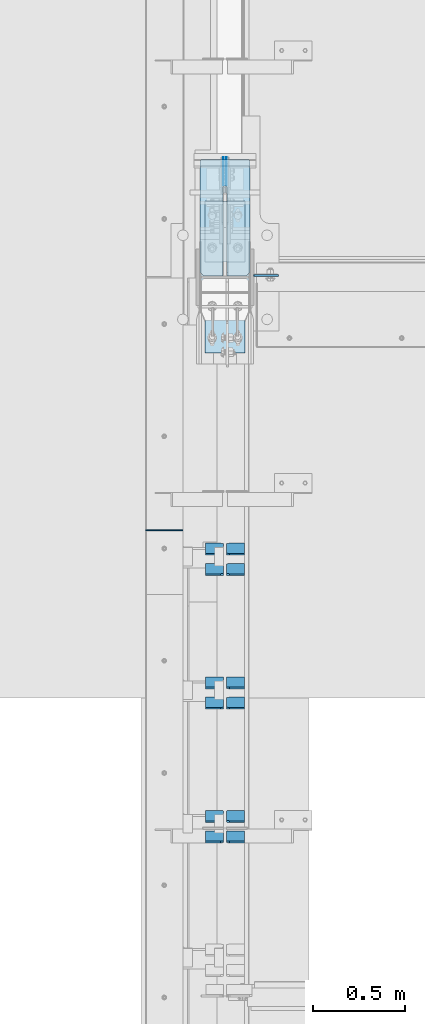
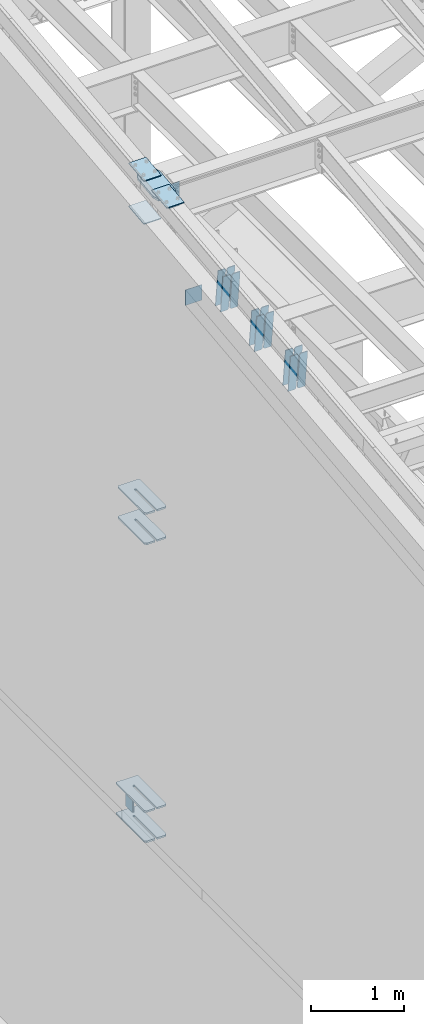
# One storey, part 1020 of 1179: 24 plates, 4 elements without a shape of their own.
"""IFC2X3 building model written with IfcOpenShell, lengths in millimetres."""

from ifc_helpers import new_model, si_unit, frame, origin_with_axes, place, context, subcontext, project, spatial, faceted_brep, material, type_object, element, aggregate, save


model = new_model("IFC2X3")

# Units and contexts
model_context = context("Model", 3, precision=1e-05, world=origin_with_axes())
body_context = subcontext(model_context, "Body", "Model", "MODEL_VIEW")
ifc_project = project(units=[si_unit("LENGTHUNIT", "METRE", prefix="MILLI"), si_unit("AREAUNIT", "SQUARE_METRE"), si_unit("VOLUMEUNIT", "CUBIC_METRE"), si_unit("MASSUNIT", "GRAM", prefix="KILO"), si_unit("TIMEUNIT", "SECOND"), si_unit("PLANEANGLEUNIT", "RADIAN"), si_unit("SOLIDANGLEUNIT", "STERADIAN"), si_unit("THERMODYNAMICTEMPERATUREUNIT", "DEGREE_CELSIUS"), si_unit("LUMINOUSINTENSITYUNIT", "LUMEN")], contexts=[model_context])

# Site, building, storey
site_placement = place(None, origin_with_axes())
site = spatial("IfcSite", under=ifc_project, at=site_placement, CompositionType="ELEMENT")
building_placement = place(site_placement, origin_with_axes())
building = spatial("IfcBuilding", under=site, at=building_placement, Name="Undefined", CompositionType="ELEMENT")
storey_placement = place(building_placement, origin_with_axes())
storey = spatial("IfcBuildingStorey", under=building, at=storey_placement, Name="Undefined", CompositionType="ELEMENT", Elevation=0.0)

# Assembly, plates
assembly_1_placement = place(storey_placement, origin_with_axes())
assembly_1 = element("IfcElementAssembly", 1, at=assembly_1_placement, inside=storey, Name="COLUMN", AssemblyPlace="NOTDEFINED", PredefinedType="RIGID_FRAME")
ifc_material_1 = material(Name="STEEL/A572-GR.50")
plate_type_1 = type_object("IfcPlateType", PredefinedType="NOTDEFINED")
plate_1_placement = place(assembly_1_placement, frame((295.274993896492, 27654.8389034115, 7605.7125), z_axis=(0.0, -1.0, 0.0), x_axis=(1.0, 0.0, 0.0)))
plate_1 = element("IfcPlate", 2, at=plate_1_placement, type_object=plate_type_1, material=ifc_material_1, Name="PLATE", context=body_context, shape_type="Brep", body=[
    faceted_brep([(125.41250610351, -11.1125000000002, 597.488903411475), (125.412506137872, -11.1125000000002, 153.988049705778), (125.412506137872, 11.1125000000002, 153.988049705778), (125.41250610351, 11.1125000000002, 597.488903411475), (126.258342274934, -11.1125000000002, 149.735606914768), (126.258342274934, 11.1125000000002, 149.735606914768), (128.667087804347, -11.1125000000002, 146.130519754093), (128.667087804347, 11.1125000000002, 146.130519754093), (132.272055845929, -11.1125000000002, 143.721595952742), (132.272055845929, 11.1125000000002, 143.721595952742), (136.524456006679, -11.1125000000002, 142.875549529541), (136.524456006679, 11.1125000000002, 142.875549529541), (140.777194472694, -11.1125000000002, 143.721280512222), (140.777194472694, 11.1125000000002, 143.721280512222), (144.382535483473, -11.1125000000002, 146.130131182439), (144.382535483473, 11.1125000000002, 146.130131182439), (146.79156443818, -11.1125000000002, 149.735353068929), (146.79156443818, 11.1125000000002, 149.735353068929), (147.63750572166, -11.1125000000002, 153.988049707568), (147.63750572166, 11.1125000000002, 153.988049707568), (147.637505687299, -11.1125000000002, 597.488903392987), (147.637505687299, 11.1125000000002, 597.488903411475), (0.0, -11.1125000000002, 575.263903030005), (22.2250003814697, -11.1125000000002, 597.488903411475), (22.2250003814697, 11.1125000000002, 597.488903411475), (0.0, 11.1125000000002, 575.263903030005), (0.0, -11.1125000000002, 15.875), (0.0, 11.1125000000002, 15.875), (6.34999990463257, -11.1125000000002, 0.0), (6.34999990463257, 11.1125000000002, 0.0), (266.699987888336, -11.1125000000002, 0.0), (266.699987888336, 11.1125000000002, 0.0), (273.049987792969, -11.1125000000002, 15.875), (273.049987792969, 11.1125000000002, 15.875), (273.050006103513, -11.1125000000002, 575.263903030005), (273.050006103513, 11.1125000000002, 575.263903030005), (250.825005722043, -11.1125000000002, 597.488903411475), (250.825005722043, 11.1125000000002, 597.488903411475)], [[[0, 1, 2, 3]], [[4, 5, 2, 1]], [[6, 7, 5, 4]], [[8, 9, 7, 6]], [[10, 11, 9, 8]], [[12, 13, 11, 10]], [[14, 15, 13, 12]], [[16, 17, 15, 14]], [[18, 19, 17, 16]], [[20, 21, 19, 18]], [[22, 23, 24, 25]], [[26, 22, 25, 27]], [[28, 26, 27, 29]], [[30, 28, 29, 31]], [[32, 30, 31, 33]], [[34, 32, 33, 35]], [[36, 34, 35, 37]], [[16, 14, 12, 10, 8, 6, 4, 1, 0, 23, 22, 26, 28, 30, 32, 34, 36, 20, 18]], [[24, 23, 0, 3]], [[37, 35, 33, 31, 29, 27, 25, 24, 3, 2, 5, 7, 9, 11, 13, 15, 17, 19, 21]], [[36, 37, 21, 20]]]),
])
plate_2_placement = place(assembly_1_placement, frame((295.274993896492, 27654.8389034115, 8002.5875), z_axis=(0.0, -1.0, 0.0), x_axis=(1.0, 0.0, 0.0)))
plate_2 = element("IfcPlate", 3, at=plate_2_placement, type_object=plate_type_1, material=ifc_material_1, Name="PLATE", context=body_context, shape_type="Brep", body=[
    faceted_brep([(125.41250610351, -11.1125000000002, 597.488903411475), (125.412506137872, -11.1125000000002, 153.988049705778), (125.412506137872, 11.1125000000002, 153.988049705778), (125.41250610351, 11.1125000000002, 597.488903411475), (126.258342274934, -11.1125000000002, 149.735606914768), (126.258342274934, 11.1125000000002, 149.735606914768), (128.667087804347, -11.1125000000002, 146.130519754093), (128.667087804347, 11.1125000000002, 146.130519754093), (132.272055845929, -11.1125000000002, 143.721595952742), (132.272055845929, 11.1125000000002, 143.721595952742), (136.524456006679, -11.1125000000002, 142.875549529541), (136.524456006679, 11.1125000000002, 142.875549529541), (140.777194472694, -11.1125000000002, 143.721280512222), (140.777194472694, 11.1125000000002, 143.721280512222), (144.382535483473, -11.1125000000002, 146.130131182439), (144.382535483473, 11.1125000000002, 146.130131182439), (146.79156443818, -11.1125000000002, 149.735353068929), (146.79156443818, 11.1125000000002, 149.735353068929), (147.63750572166, -11.1125000000002, 153.988049707568), (147.63750572166, 11.1125000000002, 153.988049707568), (147.637505687299, -11.1125000000002, 597.488903392987), (147.637505687299, 11.1125000000002, 597.488903411475), (0.0, -11.1125000000002, 575.263903030005), (22.2250003814697, -11.1125000000002, 597.488903411475), (22.2250003814697, 11.1125000000002, 597.488903411475), (0.0, 11.1125000000002, 575.263903030005), (0.0, -11.1125000000002, 15.875), (0.0, 11.1125000000002, 15.875), (6.34999990463257, -11.1125000000002, 0.0), (6.34999990463257, 11.1125000000002, 0.0), (266.699987888336, -11.1125000000002, 0.0), (266.699987888336, 11.1125000000002, 0.0), (273.049987792969, -11.1125000000002, 15.875), (273.049987792969, 11.1125000000002, 15.875), (273.050006103513, -11.1125000000002, 575.263903030005), (273.050006103513, 11.1125000000002, 575.263903030005), (250.825005722043, -11.1125000000002, 597.488903411475), (250.825005722043, 11.1125000000002, 597.488903411475)], [[[0, 1, 2, 3]], [[4, 5, 2, 1]], [[6, 7, 5, 4]], [[8, 9, 7, 6]], [[10, 11, 9, 8]], [[12, 13, 11, 10]], [[14, 15, 13, 12]], [[16, 17, 15, 14]], [[18, 19, 17, 16]], [[20, 21, 19, 18]], [[22, 23, 24, 25]], [[26, 22, 25, 27]], [[28, 26, 27, 29]], [[30, 28, 29, 31]], [[32, 30, 31, 33]], [[34, 32, 33, 35]], [[36, 34, 35, 37]], [[16, 14, 12, 10, 8, 6, 4, 1, 0, 23, 22, 26, 28, 30, 32, 34, 36, 20, 18]], [[24, 23, 0, 3]], [[37, 35, 33, 31, 29, 27, 25, 24, 3, 2, 5, 7, 9, 11, 13, 15, 17, 19, 21]], [[36, 37, 21, 20]]]),
])
plate_3_placement = place(assembly_1_placement, frame((295.275012207031, 27690.983001131, 3694.1125), z_axis=(0.0, -1.0, 0.0), x_axis=(1.0, 0.0, 0.0)))
plate_3 = element("IfcPlate", 4, at=plate_3_placement, type_object=plate_type_1, material=ifc_material_1, Name="PLATE", context=body_context, shape_type="Brep", body=[
    faceted_brep([(125.412487792972, -11.1125000000002, 633.633001130984), (125.412487792968, -11.1125000000002, 153.987500190735), (125.412487792968, 11.1125000000002, 153.987500190735), (125.412487792972, 11.1125000000002, 633.633001130984), (126.258376502454, -11.1125000000002, 149.734930475586), (126.258376502454, 11.1125000000002, 149.734930475586), (128.667263742896, -11.1125000000002, 146.12977594993), (128.667263742896, 11.1125000000002, 146.12977594993), (132.272418268556, -11.1125000000002, 143.720888709488), (132.272418268556, 11.1125000000002, 143.720888709488), (136.524987602239, -11.1125000000002, 142.875), (136.524987602239, 11.1125000000002, 142.875), (140.777557317386, -11.1125000000002, 143.720888709488), (140.777557317386, 11.1125000000002, 143.720888709488), (144.382711843045, -11.1125000000002, 146.12977594993), (144.382711843045, 11.1125000000002, 146.12977594993), (146.791599083488, -11.1125000000002, 149.734930475586), (146.791599083488, 11.1125000000002, 149.734930475586), (147.637487792974, -11.1125000000002, 153.987500190735), (147.637487792974, 11.1125000000002, 153.987500190735), (147.637487792977, -11.1125000000002, 633.633001130984), (147.637487792977, 11.1125000000002, 633.633001130984), (0.0, -11.1125000000002, 611.408000749514), (22.2250003814697, -11.1125000000002, 633.633001130984), (22.2250003814697, 11.1125000000002, 633.633001130984), (0.0, 11.1125000000002, 611.408000749514), (0.0, -11.1125000000002, 15.875), (0.0, 11.1125000000002, 15.875), (6.34999990463257, -11.1125000000002, 0.0), (6.34999990463257, 11.1125000000002, 0.0), (266.699987888336, -11.1125000000002, 0.0), (266.699987888336, 11.1125000000002, 0.0), (273.049987792969, -11.1125000000002, 15.875), (273.049987792969, 11.1125000000002, 15.875), (273.049987792969, -11.1125000000002, 611.408000749514), (273.049987792969, 11.1125000000002, 611.408000749514), (250.824987411499, -11.1125000000002, 633.633001130984), (250.824987411499, 11.1125000000002, 633.633001130984)], [[[0, 1, 2, 3]], [[4, 5, 2, 1]], [[6, 7, 5, 4]], [[8, 9, 7, 6]], [[10, 11, 9, 8]], [[12, 13, 11, 10]], [[14, 15, 13, 12]], [[16, 17, 15, 14]], [[18, 19, 17, 16]], [[20, 21, 19, 18]], [[22, 23, 24, 25]], [[26, 22, 25, 27]], [[28, 26, 27, 29]], [[30, 28, 29, 31]], [[32, 30, 31, 33]], [[34, 32, 33, 35]], [[36, 34, 35, 37]], [[16, 14, 12, 10, 8, 6, 4, 1, 0, 23, 22, 26, 28, 30, 32, 34, 36, 20, 18]], [[24, 23, 0, 3]], [[37, 35, 33, 31, 29, 27, 25, 24, 3, 2, 5, 7, 9, 11, 13, 15, 17, 19, 21]], [[36, 37, 21, 20]]]),
])
plate_4_placement = place(assembly_1_placement, frame((295.275012207031, 27690.983001131, 4090.9875), z_axis=(0.0, -1.0, 0.0), x_axis=(1.0, 0.0, 0.0)))
plate_4 = element("IfcPlate", 5, at=plate_4_placement, type_object=plate_type_1, material=ifc_material_1, Name="PLATE", context=body_context, shape_type="Brep", body=[
    faceted_brep([(125.412487792972, -11.1125000000002, 633.633001130984), (125.412487792968, -11.1125000000002, 153.987500190735), (125.412487792968, 11.1125000000002, 153.987500190735), (125.412487792972, 11.1125000000002, 633.633001130984), (126.258376502454, -11.1125000000002, 149.734930475586), (126.258376502454, 11.1125000000002, 149.734930475586), (128.667263742896, -11.1125000000002, 146.12977594993), (128.667263742896, 11.1125000000002, 146.12977594993), (132.272418268556, -11.1125000000002, 143.720888709488), (132.272418268556, 11.1125000000002, 143.720888709488), (136.524987602239, -11.1125000000002, 142.875), (136.524987602239, 11.1125000000002, 142.875), (140.777557317386, -11.1125000000002, 143.720888709488), (140.777557317386, 11.1125000000002, 143.720888709488), (144.382711843045, -11.1125000000002, 146.12977594993), (144.382711843045, 11.1125000000002, 146.12977594993), (146.791599083488, -11.1125000000002, 149.734930475586), (146.791599083488, 11.1125000000002, 149.734930475586), (147.637487792974, -11.1125000000002, 153.987500190735), (147.637487792974, 11.1125000000002, 153.987500190735), (147.637487792977, -11.1125000000002, 633.633001130984), (147.637487792977, 11.1125000000002, 633.633001130984), (0.0, -11.1125000000002, 611.408000749514), (22.2250003814697, -11.1125000000002, 633.633001130984), (22.2250003814697, 11.1125000000002, 633.633001130984), (0.0, 11.1125000000002, 611.408000749514), (0.0, -11.1125000000002, 15.875), (0.0, 11.1125000000002, 15.875), (6.34999990463257, -11.1125000000002, 0.0), (6.34999990463257, 11.1125000000002, 0.0), (266.699987888336, -11.1125000000002, 0.0), (266.699987888336, 11.1125000000002, 0.0), (273.049987792969, -11.1125000000002, 15.875), (273.049987792969, 11.1125000000002, 15.875), (273.049987792969, -11.1125000000002, 611.408000749514), (273.049987792969, 11.1125000000002, 611.408000749514), (250.824987411499, -11.1125000000002, 633.633001130984), (250.824987411499, 11.1125000000002, 633.633001130984)], [[[0, 1, 2, 3]], [[4, 5, 2, 1]], [[6, 7, 5, 4]], [[8, 9, 7, 6]], [[10, 11, 9, 8]], [[12, 13, 11, 10]], [[14, 15, 13, 12]], [[16, 17, 15, 14]], [[18, 19, 17, 16]], [[20, 21, 19, 18]], [[22, 23, 24, 25]], [[26, 22, 25, 27]], [[28, 26, 27, 29]], [[30, 28, 29, 31]], [[32, 30, 31, 33]], [[34, 32, 33, 35]], [[36, 34, 35, 37]], [[16, 14, 12, 10, 8, 6, 4, 1, 0, 23, 22, 26, 28, 30, 32, 34, 36, 20, 18]], [[24, 23, 0, 3]], [[37, 35, 33, 31, 29, 27, 25, 24, 3, 2, 5, 7, 9, 11, 13, 15, 17, 19, 21]], [[36, 37, 21, 20]]]),
])
ifc_material_2 = material(Name="STEEL/A36")
plate_type_2 = type_object("IfcPlateType", PredefinedType="NOTDEFINED")
plate_5_placement = place(assembly_1_placement, frame((588.962500000001, 27061.3187499701, 12224.9406250357), z_axis=(1.0, 0.0, 0.0), x_axis=(0.0, 0.0, -1.0)))
plate_5 = element("IfcPlate", 6, at=plate_5_placement, type_object=plate_type_2, material=ifc_material_2, Name="PLATE", context=body_context, shape_type="Brep", body=[
    faceted_brep([(0.0, -4.76249999999709, 0.0), (0.0, -4.76250000000073, 133.35), (0.0, 4.76250000000073, 133.35), (0.0, 4.76249999999709, 0.0), (317.5, -4.76250000000073, 133.350000816426), (317.5, 4.76250000000073, 133.350000816426), (317.499990657736, -4.76249999986703, 5.00222085975111e-10), (317.499990657721, 4.76250000013533, 5.00222085975111e-10)], [[[0, 1, 2, 3]], [[1, 4, 5, 2]], [[4, 6, 7, 5]], [[6, 0, 3, 7]], [[5, 7, 3, 2]], [[6, 4, 1, 0]]]),
])

# Assembly, plate
assembly_2_placement = place(storey_placement, origin_with_axes())
assembly_2 = element("IfcElementAssembly", 7, at=assembly_2_placement, inside=storey, Name="BEAM", AssemblyPlace="NOTDEFINED", PredefinedType="RIGID_FRAME")
plate_type_3 = type_object("IfcPlateType", PredefinedType="NOTDEFINED")
plate_6_placement = place(assembly_2_placement, frame((0.0, 25676.2250005413, 11892.1593821998), z_axis=(0.0, 0.0, -1.0), x_axis=(1.0, 0.0, 0.0)))
plate_6 = element("IfcPlate", 8, at=plate_6_placement, type_object=plate_type_3, material=ifc_material_2, Name="CAP_PLATE", context=body_context, shape_type="Brep", body=[
    faceted_brep([(0.0, -3.17500000000109, 0.0), (0.0, -3.17499999999927, 204.492999998953), (0.0, 3.17499999999927, 204.492999998953), (0.0, 3.17500000000109, 7.27595761418343e-12), (203.199999999997, -3.17499999999927, 204.492999998953), (203.199999999997, 3.17499999999927, 204.492999998953), (203.199999999997, -3.17499999999927, 3.63797880709171e-12), (203.199999999997, 3.17499999999382, -3.63797880709171e-12)], [[[0, 1, 2, 3]], [[1, 4, 5, 2]], [[4, 6, 7, 5]], [[6, 0, 3, 7]], [[5, 7, 3, 2]], [[6, 4, 1, 0]]]),
])
aggregate(assembly_2, [plate_6])

# Plate
plate_type_4 = type_object("IfcPlateType", PredefinedType="NOTDEFINED")
plate_7_placement = place(assembly_1_placement, frame((295.27499999975, 26814.3139130949, 12262.4277760539), z_axis=(1.0, 0.0, 0.0), x_axis=(0.0, 0.993683229349742, 0.112221387039499)))
plate_7 = element("IfcPlate", 9, at=plate_7_placement, type_object=plate_type_4, material=ifc_material_2, Name="PLATE", context=body_context, shape_type="Brep", body=[
    faceted_brep([(404.009737741189, -14.2874999996602, 8.31619217933621e-11), (71.43750000002, -14.287499999984, 2.90469870378729e-11), (71.4375000000155, 14.2874999999949, 2.90469870378729e-11), (404.009737741166, 14.2875000003405, 8.31619217933621e-11), (477.034739267168, 14.2875000004005, 30.162500381568), (473.810043726306, -14.287499999602, 28.8305609300143), (477.034739268025, 14.2875000004024, 242.887499623284), (473.810043726306, -14.287499999602, 244.219439075195), (404.009737742264, 14.2875000003405, 273.05000000474), (404.00973774229, -14.2874999996602, 273.05000000474), (71.4375000016116, -14.2874999999858, 273.049999999798), (71.4375000016071, 14.2874999999967, 273.049999999798), (4.20644072178584, 14.2875000000058, 244.663552394444), (0.979329666730337, -14.2874999999967, 243.30099437618), (0.979329666730337, -14.2874999999967, 29.7490056281208), (4.20644072178584, 14.2875000000058, 28.3864476098539)], [[[0, 1, 2, 3]], [[0, 3, 4, 5]], [[5, 4, 6, 7]], [[8, 9, 7, 6]], [[10, 9, 8, 11]], [[10, 11, 12, 13]], [[1, 0, 5, 7, 9, 10, 13, 14]], [[2, 1, 14, 15]], [[11, 8, 6, 4, 3, 2, 15, 12]], [[14, 13, 12, 15]]]),
])

# Assembly, plates
assembly_3_placement = place(storey_placement, origin_with_axes())
assembly_3 = element("IfcElementAssembly", 10, at=assembly_3_placement, inside=storey, Name="BEAM", AssemblyPlace="NOTDEFINED", PredefinedType="RIGID_FRAME")
plate_type_5 = type_object("IfcPlateType", PredefinedType="NOTDEFINED")
plate_8_placement = place(assembly_3_placement, frame((438.943750000002, 27703.683001131, 4044.95), z_axis=(0.0, 0.0, -1.0), x_axis=(0.0, -1.0, 0.0)))
plate_8 = element("IfcPlate", 11, at=plate_8_placement, type_object=plate_type_5, material=ifc_material_1, Name="PLATE", context=body_context, shape_type="Brep", body=[
    faceted_brep([(3.63797880709171e-12, -1.58750000000055, 1.81898940354586e-12), (-2.18278728425503e-11, -1.58750000000146, 304.8), (-2.18278728425503e-11, 1.58750000000146, 304.8), (-3.63797880709171e-12, 1.58750000000055, 0.0), (152.399999999994, -1.58750000000146, 304.8), (152.399999999994, 1.58750000000146, 304.8), (152.399999999994, -1.58750000000146, 0.0), (152.399999999994, 1.58750000000146, 0.0)], [[[0, 1, 2, 3]], [[1, 4, 5, 2]], [[4, 6, 7, 5]], [[6, 0, 3, 7]], [[5, 7, 3, 2]], [[6, 4, 1, 0]]]),
])
plate_9_placement = place(assembly_3_placement, frame((424.656250000002, 27703.683001131, 4044.95), z_axis=(0.0, 0.0, -1.0), x_axis=(0.0, -1.0, 0.0)))
plate_9 = element("IfcPlate", 12, at=plate_9_placement, type_object=plate_type_5, material=ifc_material_1, Name="PLATE", context=body_context, shape_type="Brep", body=[
    faceted_brep([(3.63797880709171e-12, -1.58750000000055, 1.81898940354586e-12), (-2.18278728425503e-11, -1.58750000000146, 304.8), (-2.18278728425503e-11, 1.58750000000146, 304.8), (-3.63797880709171e-12, 1.58750000000055, 0.0), (152.399999999994, -1.58750000000146, 304.8), (152.399999999994, 1.58750000000146, 304.8), (152.399999999994, -1.58750000000146, 0.0), (152.399999999994, 1.58750000000146, 0.0)], [[[0, 1, 2, 3]], [[1, 4, 5, 2]], [[4, 6, 7, 5]], [[6, 0, 3, 7]], [[5, 7, 3, 2]], [[6, 4, 1, 0]]]),
])
aggregate(assembly_3, [plate_8, plate_9])

# Plate
plate_type_6 = type_object("IfcPlateType", PredefinedType="NOTDEFINED")
plate_10_placement = place(assembly_1_placement, frame((323.850003077958, 27462.0732407573, 12356.3630183958), z_axis=(1.0, 0.0, 0.0), x_axis=(0.0, -0.993676146336441, -0.112284087038017)))
plate_10 = element("IfcPlate", 13, at=plate_10_placement, type_object=plate_type_6, material=ifc_material_1, Name="PLATE", context=body_context, shape_type="Brep", body=[
    faceted_brep([(0.0, -6.34999999999854, 0.0), (0.0, -6.350000000004, 215.899993896484), (0.0, 6.35000000000582, 215.899993896484), (0.0, 6.34999999999854, 0.0), (330.200000001782, -6.34999999994034, 215.899993896483), (330.200000001782, 6.35000000006767, 215.899993896483), (330.200000001782, -6.34999999994034, -1.47792889038101e-12), (330.200000001782, 6.35000000006767, -1.47792889038101e-12)], [[[0, 1, 2, 3]], [[1, 4, 5, 2]], [[4, 6, 7, 5]], [[6, 0, 3, 7]], [[5, 7, 3, 2]], [[6, 4, 1, 0]]]),
])

plate_11_placement = place(assembly_1_placement, frame((323.850003068441, 26640.0882512744, 12263.4798044643), z_axis=(1.0, 0.0, 0.0), x_axis=(0.0, 0.993676146336441, 0.112284087038017)))
plate_11 = element("IfcPlate", 14, at=plate_11_placement, type_object=plate_type_6, material=ifc_material_1, Name="PLATE", context=body_context, shape_type="Brep", body=[
    faceted_brep([(0.0, -6.34999999999854, 0.0), (0.0, -6.350000000004, 215.899993896484), (0.0, 6.35000000000582, 215.899993896484), (0.0, 6.34999999999854, 0.0), (330.200000001782, -6.34999999994034, 215.899993896483), (330.200000001782, 6.35000000006767, 215.899993896483), (330.200000001782, -6.34999999994034, -1.47792889038101e-12), (330.200000001782, 6.35000000006767, -1.47792889038101e-12)], [[[0, 1, 2, 3]], [[1, 4, 5, 2]], [[4, 6, 7, 5]], [[6, 0, 3, 7]], [[5, 7, 3, 2]], [[6, 4, 1, 0]]]),
])

plate_12_placement = place(assembly_1_placement, frame((323.850003061394, 27463.4992486586, 11791.0580730743), z_axis=(1.0, 0.0, 0.0), x_axis=(0.0, -0.993676146336441, -0.112284087038017)))
plate_12 = element("IfcPlate", 15, at=plate_12_placement, type_object=plate_type_6, material=ifc_material_1, Name="PLATE", context=body_context, shape_type="Brep", body=[
    faceted_brep([(0.0, -6.34999999999854, 0.0), (0.0, -6.350000000004, 215.899993896484), (0.0, 6.35000000000582, 215.899993896484), (0.0, 6.34999999999854, 0.0), (330.200000001782, -6.34999999994034, 215.899993896483), (330.200000001782, 6.35000000006767, 215.899993896483), (330.200000001782, -6.34999999994034, -1.47792889038101e-12), (330.200000001782, 6.35000000006767, -1.47792889038101e-12)], [[[0, 1, 2, 3]], [[1, 4, 5, 2]], [[4, 6, 7, 5]], [[6, 0, 3, 7]], [[5, 7, 3, 2]], [[6, 4, 1, 0]]]),
])

aggregate(assembly_1, [plate_5, plate_10, plate_11, plate_7, plate_1, plate_2, plate_3, plate_4, plate_12])

# Assembly, plates
assembly_4_placement = place(storey_placement, origin_with_axes())
assembly_4 = element("IfcElementAssembly", 16, at=assembly_4_placement, inside=storey, Name="BEAM", AssemblyPlace="NOTDEFINED", PredefinedType="RIGID_FRAME")
plate_type_7 = type_object("IfcPlateType", PredefinedType="NOTDEFINED")
plate_13_placement = place(assembly_4_placement, frame((538.162500000002, 24039.8200954736, 11436.1389286989), z_axis=(0.0, -0.112284087038017, 0.993676146336441), x_axis=(-1.0, 0.0, 0.0)))
plate_13 = element("IfcPlate", 17, at=plate_13_placement, type_object=plate_type_7, material=ifc_material_2, Name="PLATE", context=body_context, shape_type="Brep", body=[
    faceted_brep([(0.0, -4.76249999999709, 0.0), (0.0, -4.76250000020082, 498.474999998594), (0.0, 4.76249999979336, 498.474999998596), (0.0, 4.76249999999709, 0.0), (81.7562503814697, -4.76250000020082, 498.474999998594), (81.7562503814697, 4.76249999979336, 498.474999998596), (99.21875, -4.76250000019354, 481.012500380073), (99.21875, 4.76249999980064, 481.012500380079), (99.21875, -4.76250000000437, 17.4624996185212), (99.21875, 4.76249999998981, 17.4624996185248), (81.7562503814697, -4.76250000000073, 0.0), (81.7562503814697, 4.76249999999709, 3.63797880709171e-12)], [[[0, 1, 2, 3]], [[1, 4, 5, 2]], [[4, 6, 7, 5]], [[6, 8, 9, 7]], [[8, 10, 11, 9]], [[10, 0, 3, 11]], [[5, 7, 9, 11, 3, 2]], [[10, 8, 6, 4, 1, 0]]]),
])
plate_14_placement = place(assembly_4_placement, frame((424.656250000002, 24039.8200954736, 11436.1389286989), z_axis=(0.0, -0.112284087038017, 0.993676146336441), x_axis=(-1.0, 0.0, 0.0)))
plate_14 = element("IfcPlate", 18, at=plate_14_placement, type_object=plate_type_7, material=ifc_material_2, Name="PLATE", context=body_context, shape_type="Brep", body=[
    faceted_brep([(-1.81898940354586e-12, -4.76249999999345, 17.4624996185303), (0.0, -4.76250000019354, 481.012500380073), (0.0, 4.76249999980064, 481.012500380079), (1.81898940354586e-12, 4.76250000000073, 17.4624996185303), (17.4624996185303, -4.76250000020082, 498.474999998594), (17.4624996185303, 4.76249999979336, 498.474999998596), (99.2187497618652, -4.76249999998072, 498.475), (99.2187499999927, 4.76250000001892, 498.475), (99.21875, -4.76250000000073, 0.0), (99.21875, 4.76249999999709, 3.63797880709171e-12), (17.4624996185157, -4.76250000000073, 0.0), (17.4624996185212, 4.76249999999345, 0.0)], [[[0, 1, 2, 3]], [[1, 4, 5, 2]], [[4, 6, 7, 5]], [[6, 8, 9, 7]], [[8, 10, 11, 9]], [[10, 0, 3, 11]], [[5, 7, 9, 11, 3, 2]], [[10, 8, 6, 4, 1, 0]]]),
])
plate_15_placement = place(assembly_4_placement, frame((538.162500000002, 24150.2423572351, 11448.6164978709), z_axis=(0.0, -0.112284087038017, 0.993676146336441), x_axis=(-1.0, 0.0, 0.0)))
plate_15 = element("IfcPlate", 19, at=plate_15_placement, type_object=plate_type_7, material=ifc_material_2, Name="PLATE", context=body_context, shape_type="Brep", body=[
    faceted_brep([(0.0, -4.76249999999709, 0.0), (0.0, -4.76250000020082, 498.474999998594), (0.0, 4.76249999979336, 498.474999998596), (0.0, 4.76249999999709, 0.0), (81.7562503814697, -4.76250000020082, 498.474999998594), (81.7562503814697, 4.76249999979336, 498.474999998596), (99.21875, -4.76250000019354, 481.012500380073), (99.21875, 4.76249999980064, 481.012500380079), (99.21875, -4.76250000000437, 17.4624996185212), (99.21875, 4.76249999998981, 17.4624996185248), (81.7562503814697, -4.76250000000073, 0.0), (81.7562503814697, 4.76249999999709, 3.63797880709171e-12)], [[[0, 1, 2, 3]], [[1, 4, 5, 2]], [[4, 6, 7, 5]], [[6, 8, 9, 7]], [[8, 10, 11, 9]], [[10, 0, 3, 11]], [[5, 7, 9, 11, 3, 2]], [[10, 8, 6, 4, 1, 0]]]),
])
plate_16_placement = place(assembly_4_placement, frame((424.656250000002, 24150.2423572351, 11448.6164978709), z_axis=(0.0, -0.112284087038017, 0.993676146336441), x_axis=(-1.0, 0.0, 0.0)))
plate_16 = element("IfcPlate", 20, at=plate_16_placement, type_object=plate_type_7, material=ifc_material_2, Name="PLATE", context=body_context, shape_type="Brep", body=[
    faceted_brep([(-1.81898940354586e-12, -4.76249999999345, 17.4624996185303), (0.0, -4.76250000019354, 481.012500380073), (0.0, 4.76249999980064, 481.012500380079), (1.81898940354586e-12, 4.76250000000073, 17.4624996185303), (17.4624996185303, -4.76250000020082, 498.474999998594), (17.4624996185303, 4.76249999979336, 498.474999998596), (99.2187497618652, -4.76249999998072, 498.475), (99.2187499999927, 4.76250000001892, 498.475), (99.21875, -4.76250000000073, 0.0), (99.21875, 4.76249999999709, 3.63797880709171e-12), (17.4624996185157, -4.76250000000073, 0.0), (17.4624996185212, 4.76249999999345, 0.0)], [[[0, 1, 2, 3]], [[1, 4, 5, 2]], [[4, 6, 7, 5]], [[6, 8, 9, 7]], [[8, 10, 11, 9]], [[10, 0, 3, 11]], [[5, 7, 9, 11, 3, 2]], [[10, 8, 6, 4, 1, 0]]]),
])
plate_17_placement = place(assembly_4_placement, frame((538.162500000002, 24765.7268167669, 11518.1654257376), z_axis=(0.0, -0.112284087038017, 0.993676146336441), x_axis=(-1.0, 0.0, 0.0)))
plate_17 = element("IfcPlate", 21, at=plate_17_placement, type_object=plate_type_7, material=ifc_material_2, Name="PLATE", context=body_context, shape_type="Brep", body=[
    faceted_brep([(0.0, -4.76249999999709, 0.0), (0.0, -4.76250000020082, 498.474999998594), (0.0, 4.76249999979336, 498.474999998596), (0.0, 4.76249999999709, 0.0), (81.7562503814697, -4.76250000020082, 498.474999998594), (81.7562503814697, 4.76249999979336, 498.474999998596), (99.21875, -4.76250000019354, 481.012500380073), (99.21875, 4.76249999980064, 481.012500380079), (99.21875, -4.76250000000437, 17.4624996185212), (99.21875, 4.76249999998981, 17.4624996185248), (81.7562503814697, -4.76250000000073, 0.0), (81.7562503814697, 4.76249999999709, 3.63797880709171e-12)], [[[0, 1, 2, 3]], [[1, 4, 5, 2]], [[4, 6, 7, 5]], [[6, 8, 9, 7]], [[8, 10, 11, 9]], [[10, 0, 3, 11]], [[5, 7, 9, 11, 3, 2]], [[10, 8, 6, 4, 1, 0]]]),
])
plate_18_placement = place(assembly_4_placement, frame((424.656250000002, 24765.7268167669, 11518.1654257376), z_axis=(0.0, -0.112284087038017, 0.993676146336441), x_axis=(-1.0, 0.0, 0.0)))
plate_18 = element("IfcPlate", 22, at=plate_18_placement, type_object=plate_type_7, material=ifc_material_2, Name="PLATE", context=body_context, shape_type="Brep", body=[
    faceted_brep([(-1.81898940354586e-12, -4.76249999999345, 17.4624996185303), (0.0, -4.76250000019354, 481.012500380073), (0.0, 4.76249999980064, 481.012500380079), (1.81898940354586e-12, 4.76250000000073, 17.4624996185303), (17.4624996185303, -4.76250000020082, 498.474999998594), (17.4624996185303, 4.76249999979336, 498.474999998596), (99.2187497618652, -4.76249999998072, 498.475), (99.2187499999927, 4.76250000001892, 498.475), (99.21875, -4.76250000000073, 0.0), (99.21875, 4.76249999999709, 3.63797880709171e-12), (17.4624996185157, -4.76250000000073, 0.0), (17.4624996185212, 4.76249999999345, 0.0)], [[[0, 1, 2, 3]], [[1, 4, 5, 2]], [[4, 6, 7, 5]], [[6, 8, 9, 7]], [[8, 10, 11, 9]], [[10, 0, 3, 11]], [[5, 7, 9, 11, 3, 2]], [[10, 8, 6, 4, 1, 0]]]),
])
plate_19_placement = place(assembly_4_placement, frame((538.162500000002, 24876.1490785285, 11530.6429949096), z_axis=(0.0, -0.112284087038017, 0.993676146336441), x_axis=(-1.0, 0.0, 0.0)))
plate_19 = element("IfcPlate", 23, at=plate_19_placement, type_object=plate_type_7, material=ifc_material_2, Name="PLATE", context=body_context, shape_type="Brep", body=[
    faceted_brep([(0.0, -4.76249999999709, 0.0), (0.0, -4.76250000020082, 498.474999998594), (0.0, 4.76249999979336, 498.474999998596), (0.0, 4.76249999999709, 0.0), (81.7562503814697, -4.76250000020082, 498.474999998594), (81.7562503814697, 4.76249999979336, 498.474999998596), (99.21875, -4.76250000019354, 481.012500380073), (99.21875, 4.76249999980064, 481.012500380079), (99.21875, -4.76250000000437, 17.4624996185212), (99.21875, 4.76249999998981, 17.4624996185248), (81.7562503814697, -4.76250000000073, 0.0), (81.7562503814697, 4.76249999999709, 3.63797880709171e-12)], [[[0, 1, 2, 3]], [[1, 4, 5, 2]], [[4, 6, 7, 5]], [[6, 8, 9, 7]], [[8, 10, 11, 9]], [[10, 0, 3, 11]], [[5, 7, 9, 11, 3, 2]], [[10, 8, 6, 4, 1, 0]]]),
])
plate_20_placement = place(assembly_4_placement, frame((424.656250000002, 24876.1490785285, 11530.6429949096), z_axis=(0.0, -0.112284087038017, 0.993676146336441), x_axis=(-1.0, 0.0, 0.0)))
plate_20 = element("IfcPlate", 24, at=plate_20_placement, type_object=plate_type_7, material=ifc_material_2, Name="PLATE", context=body_context, shape_type="Brep", body=[
    faceted_brep([(-1.81898940354586e-12, -4.76249999999345, 17.4624996185303), (0.0, -4.76250000019354, 481.012500380073), (0.0, 4.76249999980064, 481.012500380079), (1.81898940354586e-12, 4.76250000000073, 17.4624996185303), (17.4624996185303, -4.76250000020082, 498.474999998594), (17.4624996185303, 4.76249999979336, 498.474999998596), (99.2187497618652, -4.76249999998072, 498.475), (99.2187499999927, 4.76250000001892, 498.475), (99.21875, -4.76250000000073, 0.0), (99.21875, 4.76249999999709, 3.63797880709171e-12), (17.4624996185157, -4.76250000000073, 0.0), (17.4624996185212, 4.76249999999345, 0.0)], [[[0, 1, 2, 3]], [[1, 4, 5, 2]], [[4, 6, 7, 5]], [[6, 8, 9, 7]], [[8, 10, 11, 9]], [[10, 0, 3, 11]], [[5, 7, 9, 11, 3, 2]], [[10, 8, 6, 4, 1, 0]]]),
])
plate_21_placement = place(assembly_4_placement, frame((538.162500000002, 25491.6335274441, 11600.1919215767), z_axis=(0.0, -0.112284087038017, 0.993676146336441), x_axis=(-1.0, 0.0, 0.0)))
plate_21 = element("IfcPlate", 25, at=plate_21_placement, type_object=plate_type_7, material=ifc_material_2, Name="PLATE", context=body_context, shape_type="Brep", body=[
    faceted_brep([(0.0, -4.76249999999709, 0.0), (0.0, -4.76250000020082, 498.474999998594), (0.0, 4.76249999979336, 498.474999998596), (0.0, 4.76249999999709, 0.0), (81.7562503814697, -4.76250000020082, 498.474999998594), (81.7562503814697, 4.76249999979336, 498.474999998596), (99.21875, -4.76250000019354, 481.012500380073), (99.21875, 4.76249999980064, 481.012500380079), (99.21875, -4.76250000000437, 17.4624996185212), (99.21875, 4.76249999998981, 17.4624996185248), (81.7562503814697, -4.76250000000073, 0.0), (81.7562503814697, 4.76249999999709, 3.63797880709171e-12)], [[[0, 1, 2, 3]], [[1, 4, 5, 2]], [[4, 6, 7, 5]], [[6, 8, 9, 7]], [[8, 10, 11, 9]], [[10, 0, 3, 11]], [[5, 7, 9, 11, 3, 2]], [[10, 8, 6, 4, 1, 0]]]),
])
plate_22_placement = place(assembly_4_placement, frame((424.656250000002, 25491.6335274441, 11600.1919215767), z_axis=(0.0, -0.112284087038017, 0.993676146336441), x_axis=(-1.0, 0.0, 0.0)))
plate_22 = element("IfcPlate", 26, at=plate_22_placement, type_object=plate_type_7, material=ifc_material_2, Name="PLATE", context=body_context, shape_type="Brep", body=[
    faceted_brep([(-1.81898940354586e-12, -4.76249999999345, 17.4624996185303), (0.0, -4.76250000019354, 481.012500380073), (0.0, 4.76249999980064, 481.012500380079), (1.81898940354586e-12, 4.76250000000073, 17.4624996185303), (17.4624996185303, -4.76250000020082, 498.474999998594), (17.4624996185303, 4.76249999979336, 498.474999998596), (99.2187497618652, -4.76249999998072, 498.475), (99.2187499999927, 4.76250000001892, 498.475), (99.21875, -4.76250000000073, 0.0), (99.21875, 4.76249999999709, 3.63797880709171e-12), (17.4624996185157, -4.76250000000073, 0.0), (17.4624996185212, 4.76249999999345, 0.0)], [[[0, 1, 2, 3]], [[1, 4, 5, 2]], [[4, 6, 7, 5]], [[6, 8, 9, 7]], [[8, 10, 11, 9]], [[10, 0, 3, 11]], [[5, 7, 9, 11, 3, 2]], [[10, 8, 6, 4, 1, 0]]]),
])
plate_23_placement = place(assembly_4_placement, frame((538.162500000002, 25602.0557892057, 11612.6694907487), z_axis=(0.0, -0.112284087038017, 0.993676146336441), x_axis=(-1.0, 0.0, 0.0)))
plate_23 = element("IfcPlate", 27, at=plate_23_placement, type_object=plate_type_7, material=ifc_material_2, Name="PLATE", context=body_context, shape_type="Brep", body=[
    faceted_brep([(0.0, -4.76249999999709, 0.0), (0.0, -4.76250000020082, 498.474999998594), (0.0, 4.76249999979336, 498.474999998596), (0.0, 4.76249999999709, 0.0), (81.7562503814697, -4.76250000020082, 498.474999998594), (81.7562503814697, 4.76249999979336, 498.474999998596), (99.21875, -4.76250000019354, 481.012500380073), (99.21875, 4.76249999980064, 481.012500380079), (99.21875, -4.76250000000437, 17.4624996185212), (99.21875, 4.76249999998981, 17.4624996185248), (81.7562503814697, -4.76250000000073, 0.0), (81.7562503814697, 4.76249999999709, 3.63797880709171e-12)], [[[0, 1, 2, 3]], [[1, 4, 5, 2]], [[4, 6, 7, 5]], [[6, 8, 9, 7]], [[8, 10, 11, 9]], [[10, 0, 3, 11]], [[5, 7, 9, 11, 3, 2]], [[10, 8, 6, 4, 1, 0]]]),
])
plate_24_placement = place(assembly_4_placement, frame((424.656250000002, 25602.0557892057, 11612.6694907487), z_axis=(0.0, -0.112284087038017, 0.993676146336441), x_axis=(-1.0, 0.0, 0.0)))
plate_24 = element("IfcPlate", 28, at=plate_24_placement, type_object=plate_type_7, material=ifc_material_2, Name="PLATE", context=body_context, shape_type="Brep", body=[
    faceted_brep([(-1.81898940354586e-12, -4.76249999999345, 17.4624996185303), (0.0, -4.76250000019354, 481.012500380073), (0.0, 4.76249999980064, 481.012500380079), (1.81898940354586e-12, 4.76250000000073, 17.4624996185303), (17.4624996185303, -4.76250000020082, 498.474999998594), (17.4624996185303, 4.76249999979336, 498.474999998596), (99.2187497618652, -4.76249999998072, 498.475), (99.2187499999927, 4.76250000001892, 498.475), (99.21875, -4.76250000000073, 0.0), (99.21875, 4.76249999999709, 3.63797880709171e-12), (17.4624996185157, -4.76250000000073, 0.0), (17.4624996185212, 4.76249999999345, 0.0)], [[[0, 1, 2, 3]], [[1, 4, 5, 2]], [[4, 6, 7, 5]], [[6, 8, 9, 7]], [[8, 10, 11, 9]], [[10, 0, 3, 11]], [[5, 7, 9, 11, 3, 2]], [[10, 8, 6, 4, 1, 0]]]),
])
aggregate(assembly_4, [plate_13, plate_14, plate_15, plate_16, plate_17, plate_18, plate_19, plate_20, plate_21, plate_22, plate_23, plate_24])

save(model, "model.ifc")
